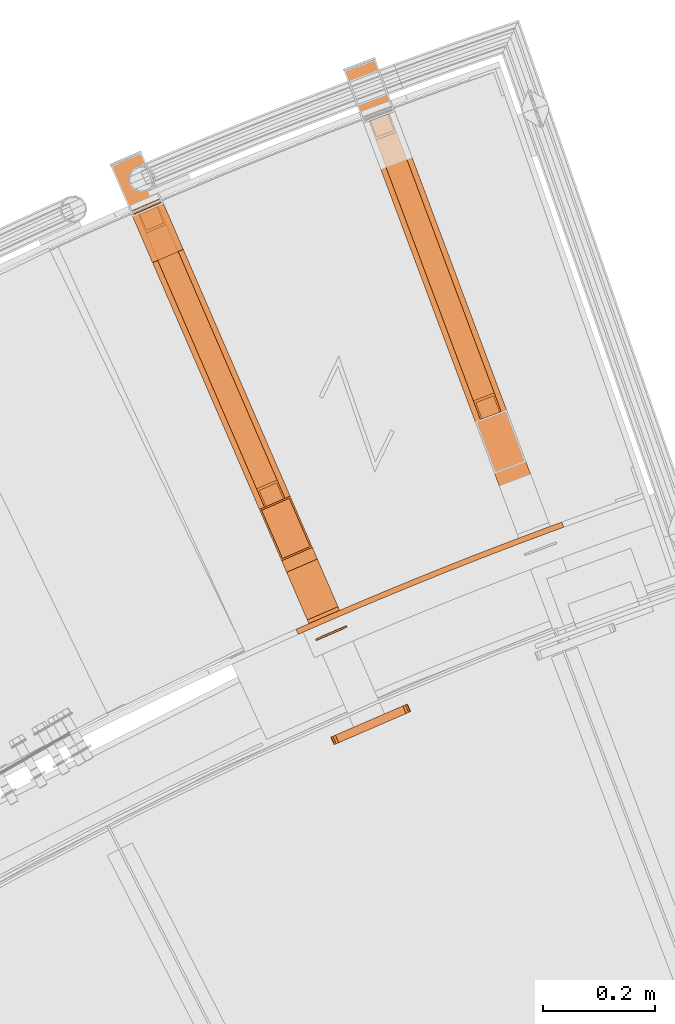
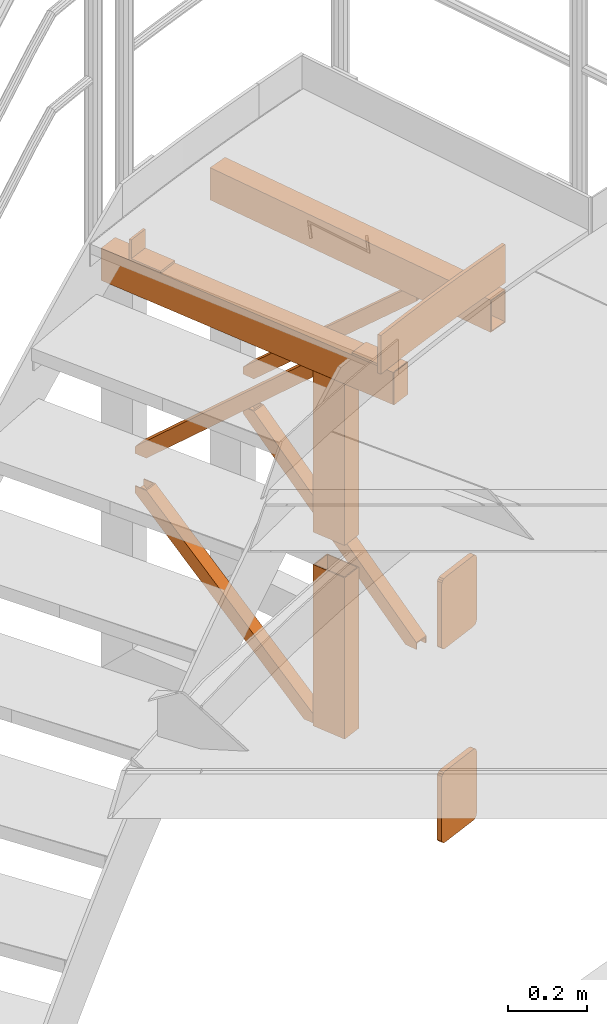
# One storey, part 83 of 126: 14 proxies.
"""IFC2X3 building model written with IfcOpenShell, lengths in millimetres."""

import ifcopenshell
import ifcopenshell.guid

model = None  # the IFC model being written
_history = None  # IfcOwnerHistory: only IFC2X3 demands one
_inside = {}  # id of a spatial element -> (the spatial element, [elements in it])
_under = {}  # id of a project, library or spatial element -> (it, [spatial elements below it])
_declared = {}  # id of a project -> (the project, [libraries it declares])
_typed = {}  # id of a type object -> (the type object, [elements of that type])
_made_of = {}  # id of a material, layer set ... -> (it, [elements and type objects made of it])


def new_model(schema):
    """Start an empty IFC model of exactly this schema.

    Asked for "IFC4X3", IfcOpenShell would pick the latest addendum, in which some entities
    have other attributes; the version numbers below select the first issue.
    IFC2X3 requires an IfcOwnerHistory on every rooted entity: one is made here for all.
    """
    global model, _history
    if schema == "IFC4X3":
        model = ifcopenshell.file(schema_version=(4, 3, 0, 0))
    else:
        model = ifcopenshell.file(schema=schema)
    _inside.clear()
    _under.clear()
    _declared.clear()
    _typed.clear()
    _made_of.clear()
    _history = None
    if model.schema == "IFC2X3":
        org = make("IfcOrganization", Name="unknown")
        user = make(
            "IfcPersonAndOrganization",
            ThePerson=make("IfcPerson", FamilyName="unknown"),
            TheOrganization=org,
        )
        app = make(
            "IfcApplication",
            ApplicationDeveloper=org,
            Version="unknown",
            ApplicationFullName="unknown",
            ApplicationIdentifier="unknown",
        )
        _history = make(
            "IfcOwnerHistory",
            OwningUser=user,
            OwningApplication=app,
            ChangeAction="ADDED",
            CreationDate=0,
        )
    return model


def make(cls, **values):
    """One entity of the class cls with the attributes given. An attribute that is None is left unset."""
    return model.create_entity(
        cls, **{name: value for name, value in values.items() if value is not None}
    )


def rooted(cls, **values):
    """An entity with a GlobalId (a new one), such as an element, a storey or a relation."""
    return make(cls, GlobalId=ifcopenshell.guid.new(), OwnerHistory=_history, **values)


def si_unit(unit_type, name, prefix=None):
    """IfcSIUnit, for example si_unit("LENGTHUNIT", "METRE", prefix="MILLI")."""
    return make("IfcSIUnit", UnitType=unit_type, Prefix=prefix, Name=name)


def assignment(units):
    """IfcUnitAssignment: the units of a project."""
    return None if units is None else make("IfcUnitAssignment", Units=units)


def point(xyz):
    """IfcCartesianPoint."""
    return None if xyz is None else make("IfcCartesianPoint", Coordinates=xyz)


def direction(xyz):
    """IfcDirection."""
    return None if xyz is None else make("IfcDirection", DirectionRatios=xyz)


def frame(location, z_axis=None, x_axis=None):
    """IfcAxis2Placement3D, a coordinate frame: its origin and axes. An axis left out is left unset."""
    return make(
        "IfcAxis2Placement3D",
        Location=point(location),
        Axis=direction(z_axis),
        RefDirection=direction(x_axis),
    )


def origin():
    """The frame at (0, 0, 0) with its axes left unset."""
    return frame((0.0, 0.0, 0.0))


def origin_with_axes():
    """The frame at (0, 0, 0) with the z axis (0, 0, 1) and the x axis (1, 0, 0) written out."""
    return frame((0.0, 0.0, 0.0), z_axis=(0.0, 0.0, 1.0), x_axis=(1.0, 0.0, 0.0))


def place(relative_to, where):
    """IfcLocalPlacement: puts the frame where relative to a parent placement (None: the world)."""
    return make(
        "IfcLocalPlacement", PlacementRelTo=relative_to, RelativePlacement=where
    )


def context(
    kind, dimensions, precision=None, world=None, true_north=None, identifier=None
):
    """IfcGeometricRepresentationContext, for example the 3D "Model" context."""
    return make(
        "IfcGeometricRepresentationContext",
        ContextIdentifier=identifier,
        ContextType=kind,
        CoordinateSpaceDimension=dimensions,
        Precision=precision,
        WorldCoordinateSystem=world,
        TrueNorth=true_north,
    )


def project(units=None, contexts=None):
    """IfcProject with its units and contexts."""
    return rooted(
        "IfcProject",
        Name="project",
        RepresentationContexts=contexts,
        UnitsInContext=assignment(units),
    )


def spatial(cls, under=None, at=None, **own):
    """A site, building, storey or space (cls), placed at a placement, below another one or the project."""
    s = rooted(cls, ObjectPlacement=at, **own)
    if under is not None:
        _under.setdefault(under.id(), (under, []))[1].append(s)
    return s


def faces_of(points, faces, orient=None, outer=None):
    """IfcFace entities. A face is a list of loops; a loop is a list of indices into points, from 0.

    orient and outer hold one flag for each loop. By default every Orientation is true, the
    first loop of a face is its IfcFaceOuterBound and the others are IfcFaceBound.
    """
    made = []
    for i, loops in enumerate(faces):
        bounds = []
        for j, loop in enumerate(loops):
            is_outer = j == 0 if outer is None else outer[i][j]
            bounds.append(
                make(
                    "IfcFaceOuterBound" if is_outer else "IfcFaceBound",
                    Bound=make("IfcPolyLoop", Polygon=[points[k] for k in loop]),
                    Orientation=True if orient is None else orient[i][j],
                )
            )
        made.append(make("IfcFace", Bounds=bounds))
    return made


def faceted_brep(points, faces, orient=None, outer=None, voids=None):
    """IfcFacetedBrep: a solid bounded by flat faces; with voids (closed shells), ...WithVoids."""
    shared = [point(p) for p in points]
    hull = make("IfcClosedShell", CfsFaces=faces_of(shared, faces, orient, outer))
    if voids is None:
        return make("IfcFacetedBrep", Outer=hull)
    return make(
        "IfcFacetedBrepWithVoids",
        Outer=hull,
        Voids=[
            make(cls, CfsFaces=faces_of(shared, fs, o, b)) for cls, fs, o, b in voids
        ],
    )


def shape(context_of_items, identifier, shape_type, items):
    """IfcShapeRepresentation: the items that make up one representation, for example the "Body"."""
    return make(
        "IfcShapeRepresentation",
        ContextOfItems=context_of_items,
        RepresentationIdentifier=identifier,
        RepresentationType=shape_type,
        Items=items,
    )


def material(Name=None, Category=None):
    """IfcMaterial."""
    return make("IfcMaterial", Name=Name, Category=Category)


def made_of(thing, what):
    """Note that an element or type object is made of a material, layer set ...; save() writes the relation."""
    if what is not None:
        _made_of.setdefault(what.id(), (what, []))[1].append(thing)
    return thing


def element(
    cls,
    number,
    at=None,
    inside=None,
    cuts=None,
    type_object=None,
    material=None,
    context=None,
    identifier="Body",
    shape_type=None,
    held_by="IfcProductDefinitionShape",
    body=None,
    shapes=None,
    **own,
):
    """One element of the class cls, such as IfcWall. Its Tag is "e" and its number.

    at: its placement. inside: the storey or other place that contains it. cuts: it is an
    opening in that element (IfcRelVoidsElement). A single representation is given by context,
    identifier, shape_type and body (its items); several are given by shapes. held_by: the class
    of the entity that holds the representations. save() writes the other relations.
    """
    e = rooted(cls, Tag="e%d" % number, ObjectPlacement=at, **own)
    if body is not None:
        shapes = [shape(context, identifier, shape_type, body)]
    if shapes is not None:
        e.Representation = make(held_by, Representations=shapes)
    if inside is not None:
        _inside.setdefault(inside.id(), (inside, []))[1].append(e)
    if cuts is not None:
        rooted(
            "IfcRelVoidsElement", RelatingBuildingElement=cuts, RelatedOpeningElement=e
        )
    if type_object is not None:
        _typed.setdefault(type_object.id(), (type_object, []))[1].append(e)
    return made_of(e, material)


def aggregate(whole, parts):
    """IfcRelAggregates: a whole, such as a stair, and the parts it consists of."""
    return rooted("IfcRelAggregates", RelatingObject=whole, RelatedObjects=parts)


def save(model, path):
    """Write the relations noted so far, then the file.

    IfcRelAggregates (storeys below a building ...), IfcRelContainedInSpatialStructure (elements
    in a storey), IfcRelDefinesByType, IfcRelAssociatesMaterial and IfcRelDeclares: one each for
    every whole, place, type object, material and project.
    """
    for whole, parts in _under.values():
        aggregate(whole, parts)
    for where, things in _inside.values():
        rooted(
            "IfcRelContainedInSpatialStructure",
            RelatedElements=things,
            RelatingStructure=where,
        )
    for kind, things in _typed.values():
        rooted("IfcRelDefinesByType", RelatedObjects=things, RelatingType=kind)
    for what, things in _made_of.values():
        rooted("IfcRelAssociatesMaterial", RelatedObjects=things, RelatingMaterial=what)
    for by, libraries in _declared.values():
        rooted("IfcRelDeclares", RelatingContext=by, RelatedDefinitions=libraries)
    model.write(path)


model = new_model("IFC2X3")

# Units and contexts
context_of_model_1 = context(None, 3, precision=0.1, world=origin())
context_of_model_2 = context(None, 3, precision=0.1, world=origin())
ifc_project = project(units=[si_unit("LENGTHUNIT", "METRE", prefix="MILLI"), si_unit("AREAUNIT", "SQUARE_METRE", prefix="CENTI"), si_unit("VOLUMEUNIT", "CUBIC_METRE", prefix="CENTI"), si_unit("MASSUNIT", "GRAM", prefix="KILO")], contexts=[context_of_model_1, context_of_model_2])

# Site, building, storey
site_placement = place(None, origin_with_axes())
site = spatial("IfcSite", under=ifc_project, at=site_placement, CompositionType="ELEMENT")
building_placement = place(site_placement, origin_with_axes())
building = spatial("IfcBuilding", under=site, at=building_placement, CompositionType="ELEMENT")
storey_placement = place(building_placement, origin_with_axes())
storey = spatial("IfcBuildingStorey", under=building, at=storey_placement, CompositionType="ELEMENT")

# Proxies
ifc_material = material(Name="S235JRG2")
proxy_1_placement = place(storey_placement, origin_with_axes())
element("IfcBuildingElementProxy", 1, at=proxy_1_placement, inside=storey, material=ifc_material, context=context_of_model_2, shape_type="Brep", body=[
    faceted_brep([(4778.2585, 15341.802, 10935.15), (4782.2845, 15332.648, 10935.15), (4773.6525, 15328.815, 10935.15), (4769.467, 15337.898, 10935.15), (4782.2845, 15332.648, 11055.0), (4773.6525, 15328.815, 11055.0), (4769.467, 15337.898, 11055.0), (4778.2585, 15341.802, 11055.0), (4829.5572, 15364.15, 10935.15), (4833.5192, 15354.968, 10935.15), (4833.5192, 15354.968, 11055.0), (4829.5572, 15364.15, 11055.0), (4881.0107, 15386.139, 10935.15), (4884.9084, 15376.93, 10935.15), (4884.9084, 15376.93, 11055.0), (4881.0107, 15386.139, 11055.0), (4932.6163, 15407.77, 10935.15), (4936.4497, 15398.533, 10935.15), (4936.4497, 15398.533, 11055.0), (4932.6163, 15407.77, 11055.0), (4984.3717, 15429.039, 10935.15), (4988.1405, 15419.776, 10935.15), (4988.1405, 15419.776, 11055.0), (4984.3717, 15429.039, 11055.0), (5036.2742, 15449.946, 10935.15), (5039.9783, 15440.657, 10935.15), (5039.9783, 15440.657, 11055.0), (5036.2742, 15449.946, 11055.0), (5088.3215, 15470.491, 10935.15), (5091.9606, 15461.177, 10935.15), (5091.9606, 15461.177, 11055.0), (5088.3215, 15470.491, 11055.0), (5140.5108, 15490.672, 10935.15), (5144.0849, 15481.333, 10935.15), (5144.0849, 15481.333, 11055.0), (5140.5108, 15490.672, 11055.0), (5192.8397, 15510.488, 10935.15), (5196.3485, 15501.124, 10935.15), (5196.3485, 15501.124, 11055.0), (5192.8397, 15510.488, 11055.0), (5245.3057, 15529.939, 10935.15), (5248.749, 15520.55, 10935.15), (5248.749, 15520.55, 11055.0), (5245.3057, 15529.939, 11055.0), (5245.3152, 15529.942, 10935.15), (5248.7583, 15520.554, 10935.15), (5248.7583, 15520.554, 11055.0), (5245.3152, 15529.942, 11055.0)], [[[0, 1, 2, 3]], [[1, 4, 5, 2]], [[0, 3, 6, 7]], [[0, 8, 9, 1]], [[1, 9, 10, 4]], [[0, 7, 11, 8]], [[8, 12, 13, 9]], [[9, 13, 14, 10]], [[8, 11, 15, 12]], [[12, 16, 17, 13]], [[13, 17, 18, 14]], [[12, 15, 19, 16]], [[16, 20, 21, 17]], [[17, 21, 22, 18]], [[16, 19, 23, 20]], [[20, 24, 25, 21]], [[21, 25, 26, 22]], [[20, 23, 27, 24]], [[24, 28, 29, 25]], [[25, 29, 30, 26]], [[24, 27, 31, 28]], [[28, 32, 33, 29]], [[29, 33, 34, 30]], [[28, 31, 35, 32]], [[32, 36, 37, 33]], [[33, 37, 38, 34]], [[32, 35, 39, 36]], [[36, 40, 41, 37]], [[37, 41, 42, 38]], [[36, 39, 43, 40]], [[40, 44, 45, 41]], [[41, 45, 46, 42]], [[40, 43, 47, 44]], [[2, 5, 6, 3]], [[5, 4, 10, 14, 18, 22, 26, 30, 34, 38, 42, 46, 47, 43, 39, 35, 31, 27, 23, 19, 15, 11, 7, 6]], [[44, 47, 46, 45]]]),
])
proxy_2_placement = place(storey_placement, origin_with_axes())
element("IfcBuildingElementProxy", 2, at=proxy_2_placement, inside=storey, material=ifc_material, context=context_of_model_2, shape_type="Brep", body=[
    faceted_brep([(4437.667, 16167.21, 10835.15), (4437.667, 16167.21, 10935.15), (4492.726, 16191.053, 10935.15), (4492.726, 16191.053, 10835.15), (4440.4199, 16168.402, 10838.15), (4489.973, 16189.861, 10838.15), (4489.973, 16189.861, 10932.15), (4440.4199, 16168.402, 10932.15), (4859.441, 15344.233, 10835.15), (4804.3819, 15320.39, 10835.15), (4859.441, 15344.233, 10935.15), (4804.3819, 15320.39, 10935.15), (4807.1349, 15321.582, 10932.15), (4807.1349, 15321.582, 10838.15), (4856.688, 15343.041, 10932.15), (4856.688, 15343.041, 10838.15)], [[[0, 1, 2, 3], [4, 5, 6, 7]], [[0, 3, 8, 9]], [[2, 10, 8, 3]], [[1, 11, 10, 2]], [[0, 9, 11, 1]], [[4, 7, 12, 13]], [[6, 14, 12, 7]], [[5, 15, 14, 6]], [[4, 13, 15, 5]], [[9, 8, 10, 11], [12, 14, 15, 13]]]),
])
proxy_3_placement = place(storey_placement, origin_with_axes())
element("IfcBuildingElementProxy", 3, at=proxy_3_placement, inside=storey, material=ifc_material, context=context_of_model_2, shape_type="Brep", body=[
    faceted_brep([(4855.1856, 16337.239, 10835.15), (4855.1856, 16337.239, 10935.15), (4911.3805, 16358.266, 10935.15), (4911.3805, 16358.266, 10835.15), (4857.9954, 16338.29, 10838.15), (4908.5707, 16357.215, 10838.15), (4908.5707, 16357.215, 10932.15), (4857.9954, 16338.29, 10932.15), (5234.7825, 15493.978, 10835.15), (5178.5877, 15472.95, 10835.15), (5234.7825, 15493.978, 10935.15), (5178.5877, 15472.95, 10935.15), (5181.3974, 15474.002, 10932.15), (5181.3974, 15474.002, 10838.15), (5231.9728, 15492.926, 10932.15), (5231.9728, 15492.926, 10838.15)], [[[0, 1, 2, 3], [4, 5, 6, 7]], [[0, 3, 8, 9]], [[2, 10, 8, 3]], [[1, 11, 10, 2]], [[0, 9, 11, 1]], [[4, 7, 12, 13]], [[6, 14, 12, 7]], [[5, 15, 14, 6]], [[4, 13, 15, 5]], [[11, 9, 8, 10], [12, 14, 15, 13]]]),
])
proxy_4_placement = place(storey_placement, origin_with_axes())
element("IfcBuildingElementProxy", 4, at=proxy_4_placement, inside=storey, material=ifc_material, context=context_of_model_2, shape_type="Brep", body=[
    faceted_brep([(4792.3998, 15348.059, 11000.15), (4792.3998, 15348.059, 10935.15), (4847.4589, 15371.902, 10935.15), (4847.4589, 15371.902, 11000.15), (4844.6771, 15378.326, 11000.15), (4789.6181, 15354.482, 11000.15), (4844.6771, 15378.326, 10942.15), (4789.6181, 15354.482, 10942.15), (4807.7201, 15463.667, 10942.15), (4752.661, 15439.824, 10942.15), (4807.7201, 15463.667, 10935.15), (4752.661, 15439.824, 10935.15)], [[[0, 1, 2, 3]], [[0, 3, 4, 5]], [[5, 4, 6, 7]], [[7, 6, 8, 9]], [[9, 8, 10, 11]], [[1, 11, 10, 2]], [[1, 0, 5, 7, 9, 11]], [[3, 2, 10, 8, 6, 4]]]),
])
proxy_5_placement = place(storey_placement, origin_with_axes())
element("IfcBuildingElementProxy", 5, at=proxy_5_placement, inside=storey, material=ifc_material, context=context_of_model_2, shape_type="Brep", body=[
    faceted_brep([(4472.9595, 16085.712, 11000.15), (4528.0186, 16109.555, 11000.15), (4528.0186, 16109.555, 10935.15), (4472.9595, 16085.712, 10935.15), (4475.7412, 16079.288, 11000.15), (4530.8003, 16103.132, 11000.15), (4475.7412, 16079.288, 10942.15), (4530.8003, 16103.132, 10942.15), (4512.6983, 15993.947, 10942.15), (4567.7574, 16017.79, 10942.15), (4512.6983, 15993.947, 10935.15), (4567.7574, 16017.79, 10935.15)], [[[0, 1, 2, 3]], [[0, 4, 5, 1]], [[4, 6, 7, 5]], [[6, 8, 9, 7]], [[8, 10, 11, 9]], [[3, 2, 11, 10]], [[3, 10, 8, 6, 4, 0]], [[1, 5, 7, 9, 11, 2]]]),
])
proxy_6_placement = place(storey_placement, origin_with_axes())
element("IfcBuildingElementProxy", 6, at=proxy_6_placement, inside=storey, material=ifc_material, Name="HANDLAUF", context=context_of_model_2, shape_type="Brep", body=[
    faceted_brep([(4949.6104, 16227.562, 10235.15), (4912.1472, 16213.544, 10235.15), (5099.3545, 15713.235, 9756.7735), (5136.8177, 15727.253, 9756.7735), (5099.3544, 15713.235, 9735.15), (4899.5964, 16247.086, 10235.15), (4899.5964, 16247.086, 10213.527), (5086.8037, 15746.777, 9735.15), (4937.0596, 16261.104, 10213.527), (5124.2669, 15760.795, 9735.15), (5136.8177, 15727.253, 9735.15), (4937.0596, 16261.104, 10235.15), (5134.0079, 15726.202, 9735.15), (5134.0079, 15726.202, 9752.7464), (4945.2247, 16230.723, 10235.15), (4934.2499, 16260.053, 10235.15), (4934.2499, 16260.053, 10217.554), (5123.0331, 15755.532, 9735.15), (4902.4061, 16248.137, 10217.554), (5091.1894, 15743.616, 9735.15), (5102.1642, 15714.286, 9735.15), (4902.4062, 16248.137, 10235.15), (4913.381, 16218.807, 10235.15), (5102.1642, 15714.286, 9752.7464)], [[[0, 1, 2, 3]], [[4, 2, 1, 5, 6, 7]], [[6, 8, 9, 7]], [[10, 9, 8, 11, 0, 3]], [[12, 13, 14, 15, 16, 17]], [[17, 16, 18, 19]], [[20, 19, 18, 21, 22, 23]], [[14, 13, 23, 22]], [[4, 7, 9, 10, 12, 17, 19, 20]], [[1, 0, 11, 15, 14, 22, 21, 5]], [[6, 5, 21, 18, 16, 15, 11, 8]], [[4, 20, 23, 13, 12, 10, 3, 2]]]),
])
proxy_7_placement = place(storey_placement, origin_with_axes())
element("IfcBuildingElementProxy", 7, at=proxy_7_placement, inside=storey, material=ifc_material, Name="HANDLAUF", context=context_of_model_2, shape_type="Brep", body=[
    faceted_brep([(4949.6104, 16227.562, 10335.15), (5136.8177, 15727.253, 10813.527), (5099.3545, 15713.235, 10813.527), (4912.1472, 16213.544, 10335.15), (5099.3544, 15713.235, 10835.15), (5086.8037, 15746.777, 10835.15), (4899.5964, 16247.086, 10356.773), (4899.5964, 16247.086, 10335.15), (5124.2669, 15760.795, 10835.15), (4937.0596, 16261.104, 10356.773), (5136.8177, 15727.253, 10835.15), (4937.0596, 16261.104, 10335.15), (5134.0079, 15726.202, 10835.15), (5123.0331, 15755.532, 10835.15), (4934.2499, 16260.053, 10352.746), (4934.2499, 16260.053, 10335.15), (4945.2247, 16230.723, 10335.15), (5134.0079, 15726.202, 10817.554), (5091.1894, 15743.616, 10835.15), (4902.4061, 16248.137, 10352.746), (5102.1642, 15714.286, 10835.15), (5102.1642, 15714.286, 10817.554), (4913.381, 16218.807, 10335.15), (4902.4062, 16248.137, 10335.15)], [[[0, 1, 2, 3]], [[4, 5, 6, 7, 3, 2]], [[6, 5, 8, 9]], [[10, 1, 0, 11, 9, 8]], [[12, 13, 14, 15, 16, 17]], [[13, 18, 19, 14]], [[20, 21, 22, 23, 19, 18]], [[16, 22, 21, 17]], [[4, 20, 18, 13, 12, 10, 8, 5]], [[3, 7, 23, 22, 16, 15, 11, 0]], [[6, 9, 11, 15, 14, 19, 23, 7]], [[4, 2, 1, 10, 12, 17, 21, 20]]]),
])
proxy_8_placement = place(storey_placement, origin_with_axes())
element("IfcBuildingElementProxy", 8, at=proxy_8_placement, inside=storey, material=ifc_material, context=context_of_model_2, shape_type="Brep", body=[
    faceted_brep([(4961.2264, 15184.683, 9575.15), (4966.4939, 15186.964, 9576.2918), (4970.9595, 15188.898, 9579.5434), (4973.9433, 15190.19, 9584.4097), (4974.9911, 15190.644, 9590.15), (4974.9911, 15190.644, 9780.15), (4973.9433, 15190.19, 9785.8902), (4970.9595, 15188.898, 9790.7566), (4966.4939, 15186.964, 9794.0082), (4961.2264, 15184.683, 9795.15), (4851.1083, 15136.996, 9795.15), (4845.8407, 15134.715, 9794.0082), (4841.3751, 15132.781, 9790.7566), (4838.3913, 15131.489, 9785.8902), (4837.3435, 15131.035, 9780.15), (4837.3435, 15131.035, 9590.15), (4838.3913, 15131.489, 9584.4097), (4841.3751, 15132.781, 9579.5434), (4845.8407, 15134.715, 9576.2918), (4851.1083, 15136.996, 9575.15), (4955.2655, 15198.447, 9575.15), (4845.1475, 15150.761, 9575.15), (4839.8799, 15148.48, 9576.2918), (4835.4143, 15146.546, 9579.5434), (4832.4305, 15145.254, 9584.4097), (4831.3827, 15144.8, 9590.15), (4831.3827, 15144.8, 9780.15), (4832.4305, 15145.254, 9785.8902), (4835.4143, 15146.546, 9790.7566), (4839.8799, 15148.48, 9794.0082), (4845.1475, 15150.761, 9795.15), (4955.2655, 15198.447, 9795.15), (4960.5331, 15200.728, 9794.0082), (4964.9987, 15202.662, 9790.7566), (4967.9825, 15203.955, 9785.8902), (4969.0303, 15204.408, 9780.15), (4969.0303, 15204.408, 9590.15), (4967.9825, 15203.955, 9584.4097), (4964.9987, 15202.662, 9579.5434), (4960.5331, 15200.728, 9576.2918)], [[[0, 1, 2, 3, 4, 5, 6, 7, 8, 9, 10, 11, 12, 13, 14, 15, 16, 17, 18, 19]], [[20, 21, 22, 23, 24, 25, 26, 27, 28, 29, 30, 31, 32, 33, 34, 35, 36, 37, 38, 39]], [[0, 20, 39, 1]], [[1, 39, 38, 2]], [[2, 38, 37, 3]], [[3, 37, 36, 4]], [[4, 36, 35, 5]], [[5, 35, 34, 6]], [[6, 34, 33, 7]], [[7, 33, 32, 8]], [[8, 32, 31, 9]], [[9, 31, 30, 10]], [[10, 30, 29, 11]], [[11, 29, 28, 12]], [[12, 28, 27, 13]], [[13, 27, 26, 14]], [[14, 26, 25, 15]], [[15, 25, 24, 16]], [[16, 24, 23, 17]], [[17, 23, 22, 18]], [[18, 22, 21, 19]], [[19, 21, 20, 0]]]),
])
proxy_9_placement = place(storey_placement, origin_with_axes())
element("IfcBuildingElementProxy", 9, at=proxy_9_placement, inside=storey, material=ifc_material, context=context_of_model_2, shape_type="Brep", body=[
    faceted_brep([(4703.917, 15552.384, 10835.15), (4758.9761, 15576.227, 10835.15), (4758.9758, 15576.228, 10335.15), (4703.9168, 15552.384, 10335.15), (4798.7149, 15484.462, 10835.15), (4798.7146, 15484.463, 10335.15), (4743.6558, 15460.619, 10835.15), (4743.6556, 15460.619, 10335.15), (4707.8621, 15550.823, 10835.15), (4745.2166, 15464.564, 10835.15), (4745.2164, 15464.565, 10335.15), (4707.8619, 15550.824, 10335.15), (4794.7698, 15486.023, 10835.15), (4794.7695, 15486.023, 10335.15), (4757.4153, 15572.282, 10835.15), (4757.415, 15572.283, 10335.15)], [[[0, 1, 2, 3]], [[1, 4, 5, 2]], [[4, 6, 7, 5]], [[0, 3, 7, 6]], [[8, 9, 10, 11]], [[9, 12, 13, 10]], [[12, 14, 15, 13]], [[8, 11, 15, 14]], [[1, 0, 6, 4], [8, 14, 12, 9]], [[7, 3, 2, 5], [10, 13, 15, 11]]]),
])
proxy_10_placement = place(storey_placement, origin_with_axes())
element("IfcBuildingElementProxy", 10, at=proxy_10_placement, inside=storey, material=ifc_material, context=context_of_model_2, shape_type="Brep", body=[
    faceted_brep([(4703.917, 15552.384, 10235.15), (4758.9761, 15576.227, 10235.15), (4758.9758, 15576.228, 9735.15), (4703.9168, 15552.384, 9735.15), (4798.7149, 15484.462, 10235.15), (4798.7146, 15484.463, 9735.15), (4743.6558, 15460.619, 10235.15), (4743.6556, 15460.619, 9735.15), (4707.8621, 15550.823, 10235.15), (4745.2166, 15464.564, 10235.15), (4745.2164, 15464.565, 9735.15), (4707.8619, 15550.824, 9735.15), (4794.7698, 15486.023, 10235.15), (4794.7695, 15486.023, 9735.15), (4757.4153, 15572.282, 10235.15), (4757.415, 15572.283, 9735.15)], [[[0, 1, 2, 3]], [[1, 4, 5, 2]], [[4, 6, 7, 5]], [[0, 3, 7, 6]], [[8, 9, 10, 11]], [[9, 12, 13, 10]], [[12, 14, 15, 13]], [[8, 11, 15, 14]], [[1, 0, 6, 4], [8, 14, 12, 9]], [[7, 3, 2, 5], [10, 13, 15, 11]]]),
])
proxy_11_placement = place(storey_placement, origin_with_axes())
element("IfcBuildingElementProxy", 11, at=proxy_11_placement, inside=storey, material=ifc_material, context=context_of_model_2, shape_type="Brep", body=[
    faceted_brep([(4860.6331, 15341.48, 10835.15), (4805.5741, 15317.637, 10835.15), (4804.3819, 15320.39, 10835.15), (4859.441, 15344.233, 10835.15), (4860.6331, 15341.48, 10935.15), (4859.441, 15344.233, 10935.15), (4804.3819, 15320.39, 10935.15), (4805.5741, 15317.637, 10935.15)], [[[0, 1, 2, 3]], [[4, 5, 6, 7]], [[0, 3, 5, 4]], [[3, 2, 6, 5]], [[2, 1, 7, 6]], [[1, 0, 4, 7]]]),
])
proxy_12_placement = place(storey_placement, origin_with_axes())
element("IfcBuildingElementProxy", 12, at=proxy_12_placement, inside=storey, material=ifc_material, context=context_of_model_2, shape_type="Brep", body=[
    faceted_brep([(4961.2264, 15184.683, 10175.15), (4966.4939, 15186.964, 10176.292), (4970.9595, 15188.898, 10179.543), (4973.9433, 15190.19, 10184.41), (4974.9911, 15190.644, 10190.15), (4974.9911, 15190.644, 10380.15), (4973.9433, 15190.19, 10385.89), (4970.9595, 15188.898, 10390.757), (4966.4939, 15186.964, 10394.008), (4961.2264, 15184.683, 10395.15), (4851.1083, 15136.996, 10395.15), (4845.8407, 15134.715, 10394.008), (4841.3751, 15132.781, 10390.757), (4838.3913, 15131.489, 10385.89), (4837.3435, 15131.035, 10380.15), (4837.3435, 15131.035, 10190.15), (4838.3913, 15131.489, 10184.41), (4841.3751, 15132.781, 10179.543), (4845.8407, 15134.715, 10176.292), (4851.1083, 15136.996, 10175.15), (4955.2655, 15198.447, 10175.15), (4845.1475, 15150.761, 10175.15), (4839.8799, 15148.48, 10176.292), (4835.4143, 15146.546, 10179.543), (4832.4305, 15145.254, 10184.41), (4831.3827, 15144.8, 10190.15), (4831.3827, 15144.8, 10380.15), (4832.4305, 15145.254, 10385.89), (4835.4143, 15146.546, 10390.757), (4839.8799, 15148.48, 10394.008), (4845.1475, 15150.761, 10395.15), (4955.2655, 15198.447, 10395.15), (4960.5331, 15200.728, 10394.008), (4964.9987, 15202.662, 10390.757), (4967.9825, 15203.955, 10385.89), (4969.0303, 15204.408, 10380.15), (4969.0303, 15204.408, 10190.15), (4967.9825, 15203.955, 10184.41), (4964.9987, 15202.662, 10179.543), (4960.5331, 15200.728, 10176.292)], [[[0, 1, 2, 3, 4, 5, 6, 7, 8, 9, 10, 11, 12, 13, 14, 15, 16, 17, 18, 19]], [[20, 21, 22, 23, 24, 25, 26, 27, 28, 29, 30, 31, 32, 33, 34, 35, 36, 37, 38, 39]], [[0, 20, 39, 1]], [[1, 39, 38, 2]], [[2, 38, 37, 3]], [[3, 37, 36, 4]], [[4, 36, 35, 5]], [[5, 35, 34, 6]], [[6, 34, 33, 7]], [[7, 33, 32, 8]], [[8, 32, 31, 9]], [[9, 31, 30, 10]], [[10, 30, 29, 11]], [[11, 29, 28, 12]], [[12, 28, 27, 13]], [[13, 27, 26, 14]], [[14, 26, 25, 15]], [[15, 25, 24, 16]], [[16, 24, 23, 17]], [[17, 23, 22, 18]], [[18, 22, 21, 19]], [[19, 21, 20, 0]]]),
])
proxy_13_placement = place(storey_placement, origin_with_axes())
element("IfcBuildingElementProxy", 13, at=proxy_13_placement, inside=storey, material=ifc_material, Name="HANDLAUF", context=context_of_model_2, shape_type="Brep", body=[
    faceted_brep([(4537.5197, 16062.451, 10235.15), (4500.8137, 16046.555, 10235.15), (4713.0933, 15556.358, 9756.7735), (4749.7993, 15572.254, 9756.7735), (4713.0933, 15556.358, 9735.15), (4486.582, 16079.419, 10235.15), (4486.582, 16079.419, 10213.527), (4698.8616, 15589.222, 9735.15), (4523.288, 16095.315, 10213.527), (4735.5676, 15605.118, 9735.15), (4749.7993, 15572.254, 9735.15), (4523.288, 16095.315, 10235.15), (4747.0463, 15571.062, 9735.15), (4747.0464, 15571.062, 9752.7464), (4532.9797, 16065.385, 10235.15), (4520.535, 16094.123, 10235.15), (4520.535, 16094.123, 10217.554), (4734.6017, 15599.799, 9735.15), (4489.3349, 16080.612, 10217.554), (4703.4016, 15586.288, 9735.15), (4715.8462, 15557.55, 9735.15), (4489.3349, 16080.611, 10235.15), (4501.7796, 16051.874, 10235.15), (4715.8462, 15557.55, 9752.7464)], [[[0, 1, 2, 3]], [[4, 2, 1, 5, 6, 7]], [[6, 8, 9, 7]], [[10, 9, 8, 11, 0, 3]], [[12, 13, 14, 15, 16, 17]], [[17, 16, 18, 19]], [[20, 19, 18, 21, 22, 23]], [[14, 13, 23, 22]], [[4, 7, 9, 10, 12, 17, 19, 20]], [[1, 0, 11, 15, 14, 22, 21, 5]], [[6, 5, 21, 18, 16, 15, 11, 8]], [[4, 20, 23, 13, 12, 10, 3, 2]]]),
])
proxy_14_placement = place(storey_placement, origin_with_axes())
element("IfcBuildingElementProxy", 14, at=proxy_14_placement, inside=storey, material=ifc_material, Name="HANDLAUF", context=context_of_model_2, shape_type="Brep", body=[
    faceted_brep([(4537.5197, 16062.451, 10335.15), (4749.7993, 15572.254, 10813.527), (4713.0933, 15556.358, 10813.527), (4500.8137, 16046.555, 10335.15), (4713.0933, 15556.358, 10835.15), (4698.8616, 15589.222, 10835.15), (4486.582, 16079.419, 10356.773), (4486.582, 16079.419, 10335.15), (4735.5676, 15605.118, 10835.15), (4523.288, 16095.315, 10356.773), (4749.7993, 15572.254, 10835.15), (4523.288, 16095.315, 10335.15), (4747.0463, 15571.062, 10835.15), (4734.6017, 15599.799, 10835.15), (4520.535, 16094.123, 10352.746), (4520.535, 16094.123, 10335.15), (4532.9797, 16065.385, 10335.15), (4747.0464, 15571.062, 10817.554), (4703.4016, 15586.288, 10835.15), (4489.3349, 16080.612, 10352.746), (4715.8462, 15557.55, 10835.15), (4715.8462, 15557.55, 10817.554), (4501.7796, 16051.874, 10335.15), (4489.3349, 16080.611, 10335.15)], [[[0, 1, 2, 3]], [[4, 5, 6, 7, 3, 2]], [[6, 5, 8, 9]], [[10, 1, 0, 11, 9, 8]], [[12, 13, 14, 15, 16, 17]], [[13, 18, 19, 14]], [[20, 21, 22, 23, 19, 18]], [[16, 22, 21, 17]], [[4, 20, 18, 13, 12, 10, 8, 5]], [[3, 7, 23, 22, 16, 15, 11, 0]], [[6, 9, 11, 15, 14, 19, 23, 7]], [[4, 2, 1, 10, 12, 17, 21, 20]]]),
])

save(model, "model.ifc")
